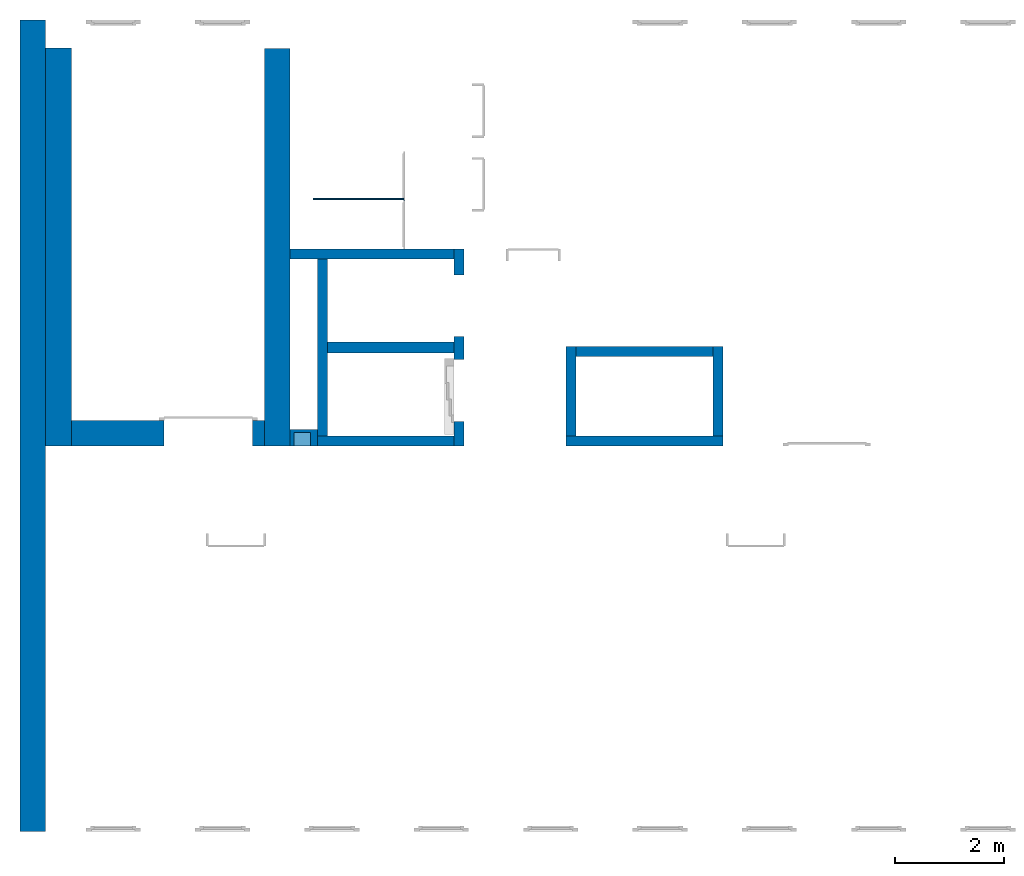
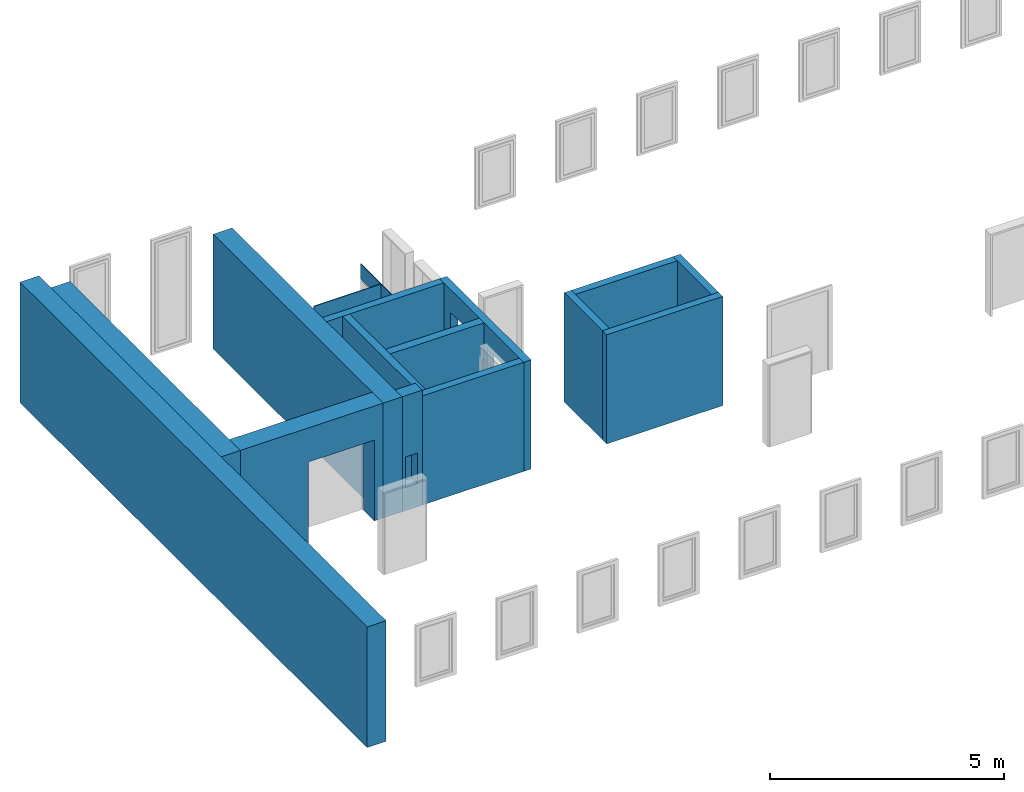
# One storey, part 1 of 5: 16 walls, 6 openings.
"""IFC4 building model written with IfcOpenShell, lengths in metres."""

from ifc_helpers import new_model, entity, si_unit, converted_unit, derived_unit, direction, frame, origin_with_axes, place, context, subcontext, project, spatial, polygons, material, type_object, element, save


model = new_model("IFC4")

# Units and contexts
model_context = context("Model", 3, precision=1e-05, world=origin_with_axes(), true_north=direction((0.0, 1.0)))
body_context = subcontext(model_context, "Body", "Model", "MODEL_VIEW")
ifc_project = project(units=[si_unit("LENGTHUNIT", "METRE"), si_unit("AREAUNIT", "SQUARE_METRE"), si_unit("VOLUMEUNIT", "CUBIC_METRE"), converted_unit("PLANEANGLEUNIT", "DEGREE", entity("IfcPlaneAngleMeasure", 0.0174532925199433), si_unit("PLANEANGLEUNIT", "RADIAN"), dimensions=[0, 0, 0, 0, 0, 0, 0]), converted_unit("TIMEUNIT", "Year", entity("IfcTimeMeasure", 31557600.0), si_unit("TIMEUNIT", "SECOND"), dimensions=[0, 0, 1, 0, 0, 0, 0]), si_unit("MASSUNIT", "GRAM", prefix="KILO"), si_unit("THERMODYNAMICTEMPERATUREUNIT", "DEGREE_CELSIUS"), si_unit("LUMINOUSINTENSITYUNIT", "LUMEN"), si_unit("ENERGYUNIT", "JOULE", prefix="MEGA"), derived_unit("THERMALCONDUCTANCEUNIT", [(si_unit("POWERUNIT", "WATT"), 1), (si_unit("LENGTHUNIT", "METRE"), -1), (si_unit("THERMODYNAMICTEMPERATUREUNIT", "KELVIN"), -1)]), derived_unit("SPECIFICHEATCAPACITYUNIT", [(si_unit("ENERGYUNIT", "JOULE"), 1), (si_unit("MASSUNIT", "GRAM", prefix="KILO"), -1), (si_unit("THERMODYNAMICTEMPERATUREUNIT", "KELVIN"), -1)]), derived_unit("MASSDENSITYUNIT", [(si_unit("MASSUNIT", "GRAM", prefix="KILO"), 1), (si_unit("VOLUMEUNIT", "CUBIC_METRE"), -1)])], contexts=[model_context])

# Site, building, storey
site_placement = place(None, origin_with_axes())
site = spatial("IfcSite", under=ifc_project, at=site_placement, CompositionType="ELEMENT")
building_placement = place(None, origin_with_axes())
building = spatial("IfcBuilding", under=site, at=building_placement, CompositionType="ELEMENT")
storey_placement = place(None, frame((0.0, 0.0, 7.5), z_axis=(0.0, 0.0, 1.0), x_axis=(1.0, 0.0, 0.0)))
storey = spatial("IfcBuildingStorey", under=building, at=storey_placement, Name="2 OG", CompositionType="ELEMENT", Elevation=7.5)

# Walls
ifc_material_1 = material(Name="Stahlbeton")
wall_type_1 = type_object("IfcWallType", Name="Stahlbeton 180", PredefinedType="NOTDEFINED")
wall_1_placement = place(None, frame((28.958, 7.05499994546755, 7.5), z_axis=(0.0, 0.0, 1.0), x_axis=(1.0, 0.0, 0.0)))
element("IfcWall", 1, at=wall_1_placement, inside=storey, type_object=wall_type_1, material=ifc_material_1, Name="Wand-001", PredefinedType="NOTDEFINED", context=body_context, shape_type="Tessellation", body=[
    polygons([(0.0, 0.0, 2.85), (2.5, 0.0, 2.85), (2.5, 0.180000000000002, 2.85), (0.0, 0.18, 2.85), (0.0, 0.0, 0.0), (2.5, 0.0, 0.0), (2.5, 0.180000000000001, 0.0), (0.0, 0.18, 0.0)], [[[1, 2, 3, 4]], [[5, 6, 2, 1]], [[6, 7, 3, 2]], [[4, 3, 7, 8]], [[5, 1, 4, 8]], [[8, 7, 6, 5]]], closed=True),
])
wall_2_placement = place(None, frame((36.373, 7.05499994546756, 7.5), z_axis=(0.0, 0.0, 1.0), x_axis=(0.0, 1.0, 0.0)))
element("IfcWall", 2, at=wall_2_placement, inside=storey, type_object=wall_type_1, material=ifc_material_1, Name="Wand-001", PredefinedType="NOTDEFINED", context=body_context, shape_type="Tessellation", body=[
    polygons([(1.818, 0.18, 0.0), (1.818, 0.18, 2.85), (1.818, 0.0, 2.85), (1.818, 0.0, 0.0), (0.180000000000001, 0.18, 0.0), (0.180000000000001, 0.18, 2.85), (0.180000000000001, 0.0, 2.85), (0.180000000000001, 0.0, 0.0)], [[[1, 2, 3, 4]], [[5, 6, 2, 1]], [[6, 7, 3, 2]], [[4, 3, 7, 8]], [[4, 8, 5, 1]], [[8, 7, 6, 5]]], closed=True),
])
wall_3_placement = place(None, frame((29.138, 7.05499994546755, 7.5), z_axis=(0.0, 0.0, 1.0), x_axis=(0.0, 1.0, 0.0)))
element("IfcWall", 3, at=wall_3_placement, inside=storey, type_object=wall_type_1, material=ifc_material_1, Name="Wand-003", PredefinedType="NOTDEFINED", context=body_context, shape_type="Tessellation", body=[
    polygons([(3.42, 0.18, 2.85), (0.180000000000001, 0.18, 2.85), (0.180000000000001, 0.0, 2.85), (3.42, 0.0, 2.85), (3.42, 0.18, 0.0), (0.18, 0.18, 0.0), (0.18, 0.0, 0.0), (3.42, 0.0, 0.0)], [[[1, 2, 3, 4]], [[5, 6, 2, 1]], [[6, 7, 3, 2]], [[4, 3, 7, 8]], [[5, 1, 4, 8]], [[8, 7, 6, 5]]], closed=True),
])

# Wall, openings
wall_4_placement = place(None, frame((31.638, 7.05499994546755, 7.5), z_axis=(0.0, 0.0, 1.0), x_axis=(0.0, 1.0, 0.0)))
wall_4 = element("IfcWall", 4, at=wall_4_placement, inside=storey, type_object=wall_type_1, material=ifc_material_1, Name="Wand-002", PredefinedType="NOTDEFINED", context=body_context, shape_type="Tessellation", body=[
    polygons([(2.0, 0.0, 0.0), (2.0, 0.0, 2.25), (3.13, 0.0, 2.25), (3.13, 0.0, 0.0), (3.6, 0.0, 0.0), (3.6, 0.0, 2.85), (0.0, 0.0, 2.85), (0.0, 0.0, 0.0), (0.450000000000002, 0.0, 0.0), (0.450000000000002, 0.0, 2.25), (1.58, 0.0, 2.25), (1.58, 0.0, 0.0), (2.0, 0.179999999999996, 0.0), (2.0, 0.179999999999996, 2.25), (3.13, 0.179999999999996, 2.25), (3.13, 0.179999999999996, 0.0), (3.6, 0.179999999999996, 0.0), (3.6, 0.179999999999996, 2.85), (0.0, 0.18, 2.85), (0.0, 0.18, 0.0), (0.450000000000002, 0.18, 0.0), (0.450000000000002, 0.18, 2.25), (1.58, 0.18, 2.25), (1.58, 0.18, 0.0)], [[[1, 2, 3, 4, 5, 6, 7, 8, 9, 10, 11, 12]], [[2, 1, 13, 14]], [[3, 2, 14, 15]], [[4, 3, 15, 16]], [[4, 16, 17, 5]], [[6, 5, 17, 18]], [[6, 18, 19, 7]], [[19, 20, 8, 7]], [[9, 8, 20, 21]], [[9, 21, 22, 10]], [[10, 22, 23, 11]], [[11, 23, 24, 12]], [[13, 1, 12, 24]], [[14, 13, 24, 23, 22, 21, 20, 19, 18, 17, 16, 15]]], closed=True),
])
opening_1_placement = place(None, frame((31.638, 9.61999994546755, 7.5), z_axis=(0.0, 0.0, 1.0), x_axis=(0.0, 1.0, 0.0)))
element("IfcOpeningElement", 5, at=opening_1_placement, cuts=wall_4, context=body_context, identifier="Reference", shape_type="Tessellation", body=[
    polygons([(-0.565, -0.00100000000000478, 2.25), (-0.565, -0.00100000000000478, 0.0), (0.565, -0.00100000000000478, 0.0), (0.565, -0.00100000000000478, 2.25), (-0.564999999999998, 0.181000000000001, 2.25), (-0.564999999999998, 0.181000000000001, 0.0), (0.565000000000001, 0.181000000000001, 0.0), (0.565000000000001, 0.181000000000001, 2.25)], [[[1, 2, 3, 4]], [[5, 6, 2, 1]], [[6, 7, 3, 2]], [[7, 8, 4, 3]], [[8, 5, 1, 4]], [[7, 6, 5, 8]]], closed=True),
])
opening_2_placement = place(None, frame((31.638, 8.06999994546756, 7.5), z_axis=(0.0, 0.0, 1.0), x_axis=(0.0, 1.0, 0.0)))
element("IfcOpeningElement", 6, at=opening_2_placement, cuts=wall_4, context=body_context, identifier="Reference", shape_type="Tessellation", body=[
    polygons([(-0.565, -0.00100000000000122, 2.25), (-0.565, -0.00100000000000122, 0.0), (0.565, -0.00100000000000122, 0.0), (0.565, -0.00100000000000122, 2.25), (-0.565, 0.181000000000004, 2.25), (-0.565, 0.181000000000004, 0.0), (0.565000000000001, 0.181000000000004, 0.0), (0.565000000000001, 0.181000000000004, 2.25)], [[[1, 2, 3, 4]], [[5, 6, 2, 1]], [[6, 7, 3, 2]], [[7, 8, 4, 3]], [[8, 5, 1, 4]], [[7, 6, 5, 8]]], closed=True),
])

# Walls
wall_5_placement = place(None, frame((36.373, 8.87299994546756, 7.5), z_axis=(0.0, 0.0, 1.0), x_axis=(-1.0, 0.0, 0.0)))
element("IfcWall", 7, at=wall_5_placement, inside=storey, type_object=wall_type_1, material=ifc_material_1, Name="Wand-001", PredefinedType="NOTDEFINED", context=body_context, shape_type="Tessellation", body=[
    polygons([(2.688, 0.18, 2.85), (0.18, 0.18, 2.85), (0.18, 0.0, 2.85), (2.688, 0.0, 2.85), (2.688, 0.18, 0.0), (0.18, 0.18, 0.0), (0.18, 0.0, 0.0), (2.688, 0.0, 0.0)], [[[1, 2, 3, 4]], [[5, 6, 2, 1]], [[6, 7, 3, 2]], [[4, 3, 7, 8]], [[5, 1, 4, 8]], [[8, 7, 6, 5]]], closed=True),
])
wall_6_placement = place(None, frame((31.638, 10.6549999454676, 7.5), z_axis=(0.0, 0.0, 1.0), x_axis=(-1.0, 0.0, 0.0)))
element("IfcWall", 8, at=wall_6_placement, inside=storey, type_object=wall_type_1, material=ifc_material_1, Name="Wand-003", PredefinedType="NOTDEFINED", context=body_context, shape_type="Tessellation", body=[
    polygons([(3.18, 0.18, 2.85), (0.179999999999996, 0.18, 2.85), (0.179999999999996, 0.0, 2.85), (3.18, 0.0, 2.85), (3.18, 0.18, 0.0), (0.179999999999996, 0.18, 0.0), (0.179999999999996, 0.0, 0.0), (3.18, 0.0, 0.0)], [[[1, 2, 3, 4]], [[5, 6, 2, 1]], [[6, 7, 3, 2]], [[4, 3, 7, 8]], [[1, 4, 8, 5]], [[8, 7, 6, 5]]], closed=True),
])
wall_7_placement = place(None, frame((33.505, 7.05499994546756, 7.5), z_axis=(0.0, 0.0, 1.0), x_axis=(1.0, 0.0, 0.0)))
element("IfcWall", 9, at=wall_7_placement, inside=storey, type_object=wall_type_1, material=ifc_material_1, Name="Wand-001", PredefinedType="NOTDEFINED", context=body_context, shape_type="Tessellation", body=[
    polygons([(0.0, 0.18, 0.0), (0.0, 0.18, 2.85), (2.868, 0.180000000000001, 2.84999999940395), (2.868, 0.180000000000001, 0.0), (0.0, 0.0, 0.0), (0.0, 0.0, 2.85), (2.868, 0.0, 2.84999999940395), (2.868, 0.0, 0.0)], [[[1, 2, 3, 4]], [[5, 6, 2, 1]], [[6, 7, 3, 2]], [[4, 3, 7, 8]], [[5, 1, 4, 8]], [[8, 7, 6, 5]]], closed=True),
])
wall_8_placement = place(None, frame((33.505, 7.05499994546756, 7.5), z_axis=(0.0, 0.0, 1.0), x_axis=(0.0, 1.0, 0.0)))
element("IfcWall", 10, at=wall_8_placement, inside=storey, type_object=wall_type_1, material=ifc_material_1, Name="Wand-001", PredefinedType="NOTDEFINED", context=body_context, shape_type="Tessellation", body=[
    polygons([(1.818, 0.0, 0.0), (1.818, 0.0, 2.85), (1.818, -0.18, 2.85), (1.818, -0.18, 0.0), (0.18, 0.0, 0.0), (0.180000000000001, 0.0, 2.85), (0.180000000000001, -0.18, 2.85), (0.18, -0.18, 0.0)], [[[1, 2, 3, 4]], [[5, 6, 2, 1]], [[6, 7, 3, 2]], [[4, 3, 7, 8]], [[4, 8, 5, 1]], [[8, 7, 6, 5]]], closed=True),
])
wall_type_2 = type_object("IfcWallType", Name="Stahlbeton 470", PredefinedType="NOTDEFINED")
wall_9_placement = place(None, frame((24.458, 14.3318657372406, 7.5), z_axis=(0.0, 0.0, 1.0), x_axis=(0.0, -1.0, 0.0)))
element("IfcWall", 11, at=wall_9_placement, inside=storey, type_object=wall_type_2, material=ifc_material_1, Name="Wand-001", PredefinedType="NOTDEFINED", context=body_context, shape_type="Tessellation", body=[
    polygons([(7.27686579177299, -0.470000000000002, 3.0), (7.27686579177299, 0.0, 3.0), (0.0, 0.0, 3.0), (0.0, -0.469999999999999, 3.0), (7.27686579177299, -0.470000000000002, 0.0), (7.27686579177299, 0.0, 0.0), (0.0, 0.0, 0.0), (0.0, -0.469999999999999, 0.0)], [[[1, 2, 3, 4]], [[2, 1, 5, 6]], [[2, 6, 7, 3]], [[8, 4, 3, 7]], [[5, 1, 4, 8]], [[6, 5, 8, 7]]], closed=True),
])
wall_10_placement = place(None, frame((23.988, 14.8459998818788, 7.35), z_axis=(0.0, 0.0, 1.0), x_axis=(0.0, -1.0, 0.0)))
element("IfcWall", 12, at=wall_10_placement, inside=storey, type_object=wall_type_2, material=ifc_material_1, Name="Wand-001", PredefinedType="NOTDEFINED", context=body_context, shape_type="Tessellation", body=[
    polygons([(0.0, 0.0, 0.0), (0.0, 0.0, 3.15), (14.8459998818788, 0.0, 3.15), (14.8459998818788, 0.0, 0.0), (0.362999990943669, 0.0, 3.0), (0.362999990943669, 0.0, 2.63), (7.79099993641123, 0.0, 2.63), (14.4829998818788, 0.0, 2.63), (14.4829998818788, 0.0, 3.0), (7.79099993641123, 0.0, 3.0), (0.0, -0.469999999999999, 0.0), (0.0, -0.469999999999999, 3.15), (14.8459998818788, -0.469999999999999, 3.15), (14.8459998818788, -0.469999999999999, 0.0), (0.362999990943669, -0.100000000000012, 2.63), (0.362999990943669, -0.100000000000012, 3.0), (14.4829998818788, -0.100000000000005, 2.63), (14.4829998818788, -0.100000000000005, 3.0)], [[[1, 2, 3, 4], [5, 6, 7, 8, 9, 10]], [[1, 11, 12, 2]], [[2, 12, 13, 3]], [[4, 3, 13, 14]], [[11, 1, 4, 14]], [[15, 6, 5, 16]], [[8, 7, 6, 15, 17]], [[18, 9, 8, 17]], [[18, 16, 5, 10, 9]], [[12, 11, 14, 13]], [[17, 15, 16, 18]]], closed=True),
])

# Wall, opening
wall_11_placement = place(None, frame((24.458, 7.52499994546755, 7.5), z_axis=(0.0, 0.0, 1.0), x_axis=(1.0, 0.0, 0.0)))
wall_11 = element("IfcWall", 13, at=wall_11_placement, inside=storey, type_object=wall_type_2, material=ifc_material_1, Name="Wand-001", PredefinedType="NOTDEFINED", context=body_context, shape_type="Tessellation", body=[
    polygons([(1.69000000000001, 0.0, 2.11), (1.69000000000001, 0.0, 0.0), (0.0, 0.0, 0.0), (0.0, 0.0, 3.0), (3.53, 0.0, 3.0), (3.53, 0.0, 0.0), (3.31, 0.0, 0.0), (3.31, 0.0, 2.11), (1.69000000000001, -0.47, 2.11), (1.69000000000001, -0.47, 0.0), (0.0, -0.47, 0.0), (0.0, -0.47, 3.0), (3.53, -0.47, 3.0), (3.53, -0.47, 0.0), (3.31, -0.47, 0.0), (3.31, -0.47, 2.11)], [[[1, 2, 3, 4, 5, 6, 7, 8]], [[2, 1, 9, 10]], [[2, 10, 11, 3]], [[12, 4, 3, 11]], [[5, 4, 12, 13]], [[13, 14, 6, 5]], [[15, 7, 6, 14]], [[8, 7, 15, 16]], [[1, 8, 16, 9]], [[16, 15, 14, 13, 12, 11, 10, 9]]], closed=True),
])
opening_3_placement = place(wall_11_placement, frame((2.5, 0.0, 0.0), z_axis=(0.0, 0.0, 1.0), x_axis=(1.0, 0.0, 0.0)))
element("IfcOpeningElement", 14, at=opening_3_placement, cuts=wall_11, context=body_context, identifier="Reference", shape_type="Tessellation", body=[
    polygons([(-0.809999999999999, -0.471, 2.11), (-0.809999999999999, -0.471, 0.0), (0.809999999999999, -0.471, 0.0), (0.809999999999999, -0.471, 2.11), (-0.809999999999999, 0.00100000000000033, 2.11), (-0.809999999999999, 0.00100000000000033, 0.0), (0.809999999999999, 0.00100000000000033, 0.0), (0.809999999999999, 0.00100000000000033, 2.11)], [[[1, 2, 3, 4]], [[5, 6, 2, 1]], [[6, 7, 3, 2]], [[7, 8, 4, 3]], [[8, 5, 1, 4]], [[7, 6, 5, 8]]], closed=True),
])

# Walls
wall_12_placement = place(None, frame((27.988, 14.3259998818788, 7.5), z_axis=(0.0, 0.0, 1.0), x_axis=(0.0, -1.0, 0.0)))
element("IfcWall", 15, at=wall_12_placement, inside=storey, type_object=wall_type_2, material=ifc_material_1, Name="Wand-001", PredefinedType="NOTDEFINED", context=body_context, shape_type="Tessellation", body=[
    polygons([(7.27099993641123, 0.469999999999999, 0.0), (7.27099993641123, 0.0, 0.0), (0.0, 0.0, 0.0), (0.0, 0.469999999999999, 0.0), (7.27099993641123, 0.469999999999999, 3.0), (7.27099993641123, 0.0, 3.0), (0.0, 0.0, 3.0), (0.0, 0.469999999999999, 3.0)], [[[1, 2, 3, 4]], [[2, 1, 5, 6]], [[2, 6, 7, 3]], [[8, 4, 3, 7]], [[5, 1, 4, 8]], [[6, 5, 8, 7]]], closed=True),
])
wall_type_3 = type_object("IfcWallType", Name="Stahlbeton 200", PredefinedType="NOTDEFINED")
wall_13_placement = place(None, frame((29.138, 8.85499994546755, 7.5), z_axis=(0.0, 0.0, 1.0), x_axis=(1.0, 0.0, 0.0)))
element("IfcWall", 16, at=wall_13_placement, inside=storey, type_object=wall_type_3, material=ifc_material_1, Name="Wand-001", PredefinedType="NOTDEFINED", context=body_context, shape_type="Tessellation", body=[
    polygons([(2.32, 0.0999999999999996, 0.0), (0.0, 0.0999999999999996, 0.0), (0.0, 0.0999999999999996, 2.85), (2.32, 0.0999999999999996, 2.85), (2.32, -0.0999999999999996, 0.0), (0.0, -0.0999999999999996, 0.0), (0.0, -0.0999999999999996, 2.85), (2.32, -0.0999999999999996, 2.85)], [[[1, 2, 3, 4]], [[5, 6, 2, 1]], [[6, 7, 3, 2]], [[4, 3, 7, 8]], [[5, 1, 4, 8]], [[8, 7, 6, 5]]], closed=True),
])

# Wall, opening
wall_type_4 = type_object("IfcWallType", Name="Stahlbeton 300", PredefinedType="NOTDEFINED")
wall_14_placement = place(None, frame((28.458, 7.05499994546755, 7.5), z_axis=(0.0, 0.0, 1.0), x_axis=(1.0, 0.0, 0.0)))
wall_14 = element("IfcWall", 17, at=wall_14_placement, inside=storey, type_object=wall_type_4, material=ifc_material_1, Name="Wand-001", PredefinedType="NOTDEFINED", context=body_context, shape_type="Tessellation", body=[
    polygons([(0.5, 0.0, 3.0), (0.0, 0.0, 3.0), (0.0, 0.0, 0.0), (0.5, 0.0, 0.0), (0.375425898351669, 0.0, 1.4), (0.375425898351669, 0.0, 0.6), (0.0754258983516713, 0.0, 0.6), (0.0754258983516713, 0.0, 1.4), (0.5, 0.3, 3.0), (0.0, 0.3, 3.0), (0.0, 0.3, 0.0), (0.5, 0.3, 0.0), (0.375425898351669, 0.25, 1.4), (0.375425898351669, 0.25, 0.6), (0.0754258983516713, 0.25, 0.6), (0.0754258983516713, 0.25, 1.4)], [[[1, 2, 3, 4], [5, 6, 7, 8]], [[9, 10, 2, 1]], [[3, 2, 10, 11]], [[4, 3, 11, 12]], [[9, 1, 4, 12]], [[13, 14, 6, 5]], [[14, 15, 7, 6]], [[15, 16, 8, 7]], [[16, 13, 5, 8]], [[12, 11, 10, 9]], [[16, 15, 14, 13]]], closed=True),
])
opening_4_placement = place(None, origin_with_axes())
element("IfcOpeningElement", 18, at=opening_4_placement, cuts=wall_14, PredefinedType="NOTDEFINED", context=body_context, identifier="Reference", shape_type="Tessellation", body=[
    polygons([(28.5334258983517, 7.30499994546755, 8.1), (28.8334258983517, 7.30499994546755, 8.1), (28.8334258983517, 6.75499994546755, 8.1), (28.5334258983517, 6.75499994546755, 8.1), (28.5334258983517, 7.30499994546755, 8.9), (28.8334258983517, 7.30499994546755, 8.9), (28.8334258983517, 6.75499994546755, 8.9), (28.5334258983517, 6.75499994546755, 8.9)], [[[1, 2, 3, 4]], [[1, 5, 6, 2]], [[2, 6, 7, 3]], [[4, 3, 7, 8]], [[5, 1, 4, 8]], [[6, 5, 8, 7]]], closed=True),
])

# Space
space_placement = place(None, frame((28.883, 12.4404999136732, 7.5), z_axis=(0.0, 0.0, 1.0), x_axis=(0.0, -1.0, 0.0)))
space = spatial("IfcSpace", under=storey, at=space_placement, CompositionType="ELEMENT", PredefinedType="NOTDEFINED")

# Wall, openings
ifc_material_2 = material(Name="Kunststoff")
wall_type_5 = type_object("IfcWallType", Name="Kunststoff 20", PredefinedType="NOTDEFINED")
wall_15_placement = place(None, frame((30.553, 10.6549999454676, 7.35), z_axis=(0.0, 0.0, 1.0), x_axis=(0.0, 1.0, 0.0)))
wall_15 = element("IfcWall", 19, at=wall_15_placement, inside=space, type_object=wall_type_5, material=ifc_material_2, Name="Wand-003", PredefinedType="NOTDEFINED", context=body_context, shape_type="Tessellation", body=[
    polygons([(0.895499968205613, 0.0, 0.15), (0.895499968205613, 0.0, 2.245), (1.78549996820561, 0.0, 2.245), (1.78549996820561, 0.0, 2.63), (0.0, 0.0, 2.63), (0.0, 0.0, 2.245), (0.890000000000001, 0.0, 2.245), (0.890000000000001, 0.0, 0.15), (0.895499968205613, 0.0199999999999996, 0.15), (0.895499968205613, 0.0199999999999996, 2.245), (1.78549996820561, 0.0199999999999996, 2.245), (1.78549996820561, 0.0199999999999996, 2.63), (0.0, 0.0199999999999996, 2.63), (0.0, 0.0199999999999996, 2.245), (0.890000000000001, 0.0199999999999996, 2.245), (0.890000000000001, 0.0199999999999996, 0.15)], [[[1, 2, 3, 4, 5, 6, 7, 8]], [[2, 1, 9, 10]], [[11, 3, 2, 10]], [[3, 11, 12, 4]], [[13, 5, 4, 12]], [[6, 5, 13, 14]], [[6, 14, 15, 7]], [[7, 15, 16, 8]], [[9, 1, 8, 16]], [[10, 9, 16, 15, 14, 13, 12, 11]]], closed=True),
])
opening_5_placement = place(wall_15_placement, frame((1.34049996820561, 0.0, 0.2), z_axis=(0.0, 0.0, 1.0), x_axis=(1.0, 0.0, 0.0)))
element("IfcOpeningElement", 20, at=opening_5_placement, cuts=wall_15, context=body_context, identifier="Reference", shape_type="Tessellation", body=[
    polygons([(0.445, 0.0210000000000008, 2.045), (0.445, 0.0210000000000008, -0.0499999999999998), (-0.445, 0.0210000000000008, -0.0499999999999998), (-0.445, 0.0210000000000008, 2.045), (0.445, -0.00100000000000122, 2.045), (0.445, -0.00100000000000122, -0.0499999999999998), (-0.445, -0.00100000000000122, -0.0499999999999998), (-0.445, -0.00100000000000122, 2.045)], [[[1, 2, 3, 4]], [[5, 6, 2, 1]], [[6, 7, 3, 2]], [[7, 8, 4, 3]], [[8, 5, 1, 4]], [[7, 6, 5, 8]]], closed=True),
])
opening_6_placement = place(wall_15_placement, frame((0.445, 0.0, 0.2), z_axis=(0.0, 0.0, 1.0), x_axis=(1.0, 0.0, 0.0)))
element("IfcOpeningElement", 21, at=opening_6_placement, cuts=wall_15, context=body_context, identifier="Reference", shape_type="Tessellation", body=[
    polygons([(0.445, 0.0210000000000008, 2.045), (0.445, 0.0210000000000008, -0.0499999999999998), (-0.445, 0.0210000000000008, -0.0499999999999998), (-0.445, 0.0210000000000008, 2.045), (0.445, -0.00100000000000122, 2.045), (0.445, -0.00100000000000122, -0.0499999999999998), (-0.445, -0.00100000000000122, -0.0499999999999998), (-0.445, -0.00100000000000122, 2.045)], [[[1, 2, 3, 4]], [[5, 6, 2, 1]], [[6, 7, 3, 2]], [[7, 8, 4, 3]], [[8, 5, 1, 4]], [[7, 6, 5, 8]]], closed=True),
])

# Wall
wall_16_placement = place(None, frame((30.553, 11.5727499295704, 7.35), z_axis=(0.0, 0.0, 1.0), x_axis=(-1.0, 0.0, 0.0)))
element("IfcWall", 22, at=wall_16_placement, inside=space, type_object=wall_type_5, material=ifc_material_2, Name="Wand-003", PredefinedType="NOTDEFINED", context=body_context, shape_type="Tessellation", body=[
    polygons([(0.0199999999999996, -0.00999999999999979, 2.63), (0.0199999999999996, 0.00999999999999979, 2.63), (0.0199999999999996, 0.00999999999999979, 0.15), (0.0199999999999996, -0.00999999999999979, 0.15), (1.67, -0.00999999999999979, 2.63), (1.67, 0.00999999999999979, 2.63), (1.67, 0.00999999999999979, 0.15), (1.67, -0.00999999999999979, 0.15)], [[[1, 2, 3, 4]], [[2, 1, 5, 6]], [[2, 6, 7, 3]], [[3, 7, 8, 4]], [[5, 1, 4, 8]], [[6, 5, 8, 7]]], closed=True),
])

save(model, "model.ifc")
